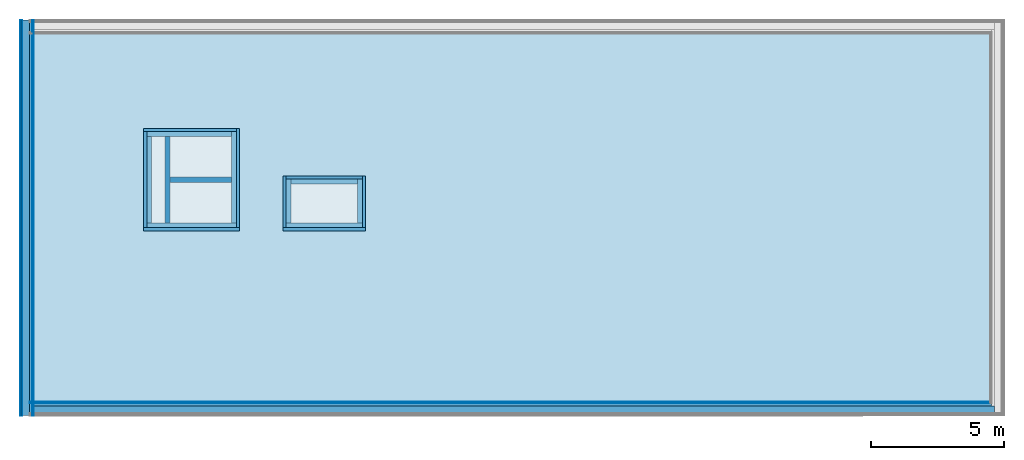
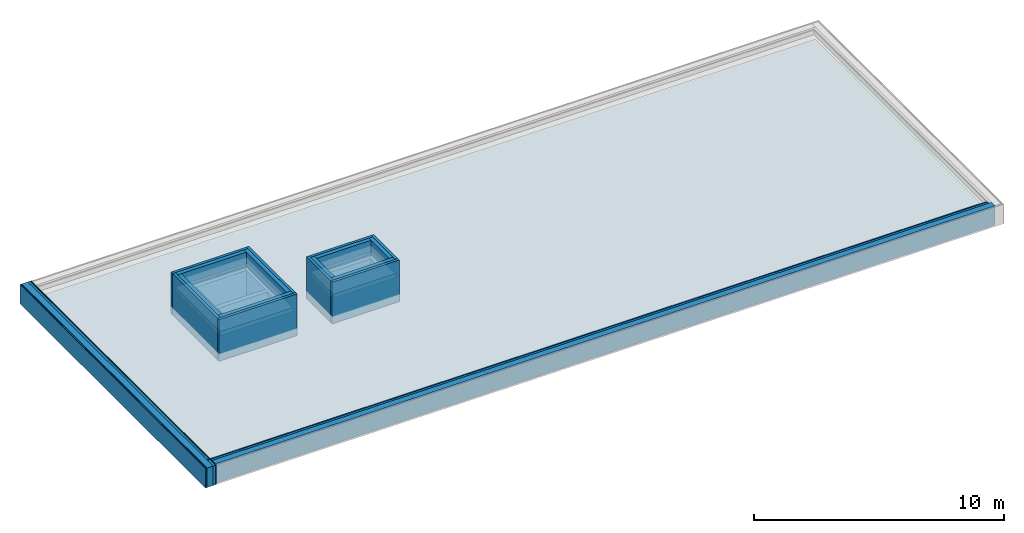
# One storey, part 1 of 3: 29 building element parts, 3 roofs, 2 walls, 10 elements without a shape of their own.
"""IFC4 building model written with IfcOpenShell, lengths in metres."""

from ifc_helpers import new_model, entity, si_unit, converted_unit, derived_unit, direction, frame, origin_with_axes, place, context, subcontext, project, spatial, polygons, material, type_object, element, aggregate, save


model = new_model("IFC4")

# Units and contexts
model_context = context("Model", 3, precision=1e-05, world=origin_with_axes(), true_north=direction((0.0, 1.0)))
body_context = subcontext(model_context, "Body", "Model", "MODEL_VIEW")
ifc_project = project(units=[si_unit("LENGTHUNIT", "METRE"), si_unit("AREAUNIT", "SQUARE_METRE"), si_unit("VOLUMEUNIT", "CUBIC_METRE"), converted_unit("PLANEANGLEUNIT", "DEGREE", entity("IfcPlaneAngleMeasure", 0.0174532925199433), si_unit("PLANEANGLEUNIT", "RADIAN"), dimensions=[0, 0, 0, 0, 0, 0, 0]), converted_unit("TIMEUNIT", "Year", entity("IfcTimeMeasure", 31557600.0), si_unit("TIMEUNIT", "SECOND"), dimensions=[0, 0, 1, 0, 0, 0, 0]), si_unit("MASSUNIT", "GRAM", prefix="KILO"), si_unit("THERMODYNAMICTEMPERATUREUNIT", "DEGREE_CELSIUS"), si_unit("LUMINOUSINTENSITYUNIT", "LUMEN"), si_unit("ENERGYUNIT", "JOULE", prefix="MEGA"), derived_unit("THERMALCONDUCTANCEUNIT", [(si_unit("POWERUNIT", "WATT"), 1), (si_unit("LENGTHUNIT", "METRE"), -1), (si_unit("THERMODYNAMICTEMPERATUREUNIT", "KELVIN"), -1)]), derived_unit("SPECIFICHEATCAPACITYUNIT", [(si_unit("ENERGYUNIT", "JOULE"), 1), (si_unit("MASSUNIT", "GRAM", prefix="KILO"), -1), (si_unit("THERMODYNAMICTEMPERATUREUNIT", "KELVIN"), -1)]), derived_unit("MASSDENSITYUNIT", [(si_unit("MASSUNIT", "GRAM", prefix="KILO"), 1), (si_unit("VOLUMEUNIT", "CUBIC_METRE"), -1)])], contexts=[model_context])

# Site, building, storey
site_placement = place(None, origin_with_axes())
site = spatial("IfcSite", under=ifc_project, at=site_placement, CompositionType="ELEMENT")
building_placement = place(site_placement, origin_with_axes())
building = spatial("IfcBuilding", under=site, at=building_placement, CompositionType="ELEMENT")
storey_placement = place(building_placement, frame((0.0, 0.0, 13.5), z_axis=(0.0, 0.0, 1.0), x_axis=(1.0, 0.0, 0.0)))
storey = spatial("IfcBuildingStorey", under=building, at=storey_placement, Name="Dach", CompositionType="ELEMENT", Elevation=13.5)

# Walls
ifc_material_1 = material(Name="Stahlbeton")
wall_type_1 = type_object("IfcWallType", Name="Stahlbeton 200", PredefinedType="NOTDEFINED")
wall_1_placement = place(storey_placement, frame((29.138, 8.85499994546755, 0.0), z_axis=(0.0, 0.0, 1.0), x_axis=(1.0, 0.0, 0.0)))
element("IfcWall", 1, at=wall_1_placement, inside=storey, type_object=wall_type_1, material=ifc_material_1, Name="Wand-001", PredefinedType="NOTDEFINED", context=body_context, shape_type="Tessellation", body=[
    polygons([(0.0, 0.0999999999999996, 0.0), (2.32, 0.0999999999999996, 0.0), (2.32, -0.0999999999999996, 0.0), (0.0, -0.0999999999999996, 0.0), (0.0, 0.0999999999999996, 1.5), (2.32, 0.0999999999999996, 1.5), (2.32, -0.0999999999999996, 1.5), (0.0, -0.0999999999999996, 1.5)], [[[1, 2, 3, 4]], [[5, 6, 2, 1]], [[7, 3, 2, 6]], [[4, 3, 7, 8]], [[8, 5, 1, 4]], [[8, 7, 6, 5]]], closed=True),
])
wall_type_2 = type_object("IfcWallType", Name="Stahlbeton 180", PredefinedType="NOTDEFINED")
wall_2_placement = place(storey_placement, frame((29.138, 6.93499994546755, 0.0), z_axis=(0.0, 0.0, 1.0), x_axis=(0.0, 1.0, 0.0)))
element("IfcWall", 2, at=wall_2_placement, inside=storey, type_object=wall_type_2, material=ifc_material_1, Name="Wand-001", PredefinedType="NOTDEFINED", context=body_context, shape_type="Tessellation", body=[
    polygons([(0.3, 0.18, 0.0), (3.54, 0.18, 0.0), (3.54, 0.0, 0.0), (0.3, 0.0, 0.0), (0.3, 0.18, 1.5), (3.54, 0.18, 1.5), (3.54, 0.0, 1.5), (0.3, 0.0, 1.5)], [[[1, 2, 3, 4]], [[5, 6, 2, 1]], [[7, 3, 2, 6]], [[4, 3, 7, 8]], [[8, 5, 1, 4]], [[8, 7, 6, 5]]], closed=True),
])

# Roofs
ifc_material_2 = material(Name="Stahlbeton Decke")
roof_type_1 = type_object("IfcRoofType", Name="Stahlbeton Decke 370", PredefinedType="FLAT_ROOF")
roof_1_placement = place(storey_placement, frame((23.888, 0.362999999999999, 0.370000000000001), z_axis=(0.0, 0.0, 1.0), x_axis=(1.0, 0.0, 0.0)))
element("IfcRoof", 3, at=roof_1_placement, inside=storey, type_object=roof_type_1, material=ifc_material_2, Name="Decke-001", PredefinedType="FLAT_ROOF", context=body_context, shape_type="Tessellation", body=[
    polygons([(0.0, 0.0, 0.0), (0.0, 0.0, -0.369999999999999), (36.195, 0.0, -0.369999999999999), (36.195, 0.0, 0.0), (0.0, 14.1199998909351, 0.0), (0.0, 14.1199998909351, -0.369999999999999), (36.195, 14.1199998909351, -0.369999999999999), (7.75000000000001, 10.2919999454676, -0.369999999999999), (4.39000000000001, 10.2919999454676, -0.369999999999999), (4.39000000000001, 6.69199994546756, -0.369999999999999), (7.75000000000001, 6.69199994546756, -0.369999999999999), (12.485, 6.69199994546755, -0.369999999999999), (12.485, 8.50999994546756, -0.369999999999999), (9.617, 8.50999994546756, -0.369999999999999), (9.617, 6.69199994546755, -0.369999999999999), (36.195, 14.1199998909351, 0.0), (4.39000000000001, 6.69199994546756, 0.0), (4.39000000000001, 10.2919999454676, 0.0), (7.75000000000001, 10.2919999454676, 0.0), (7.75000000000001, 6.69199994546756, 0.0), (9.617, 8.50999994546756, 0.0), (12.485, 8.50999994546756, 0.0), (12.485, 6.69199994546755, 0.0), (9.617, 6.69199994546755, 0.0)], [[[1, 2, 3, 4]], [[5, 6, 2, 1]], [[3, 2, 6, 7], [8, 9, 10, 11], [12, 13, 14, 15]], [[4, 3, 7, 16]], [[5, 1, 4, 16], [17, 18, 19, 20], [21, 22, 23, 24]], [[16, 7, 6, 5]], [[18, 9, 8, 19]], [[17, 10, 9, 18]], [[20, 11, 10, 17]], [[19, 8, 11, 20]], [[22, 13, 12, 23]], [[21, 14, 13, 22]], [[24, 15, 14, 21]], [[23, 12, 15, 24]]], closed=True),
])
roof_type_2 = type_object("IfcRoofType", Name="Stahlbeton Decke 200", PredefinedType="FLAT_ROOF")
roof_2_placement = place(storey_placement, frame((28.278, 7.05499994546756, 1.7), z_axis=(0.0, 0.0, 1.0), x_axis=(1.0, 0.0, 0.0)))
element("IfcRoof", 4, at=roof_2_placement, inside=storey, type_object=roof_type_2, material=ifc_material_2, Name="Decke-001", PredefinedType="FLAT_ROOF", context=body_context, shape_type="Tessellation", body=[
    polygons([(0.0, 0.0, 0.0), (0.0, 0.0, -0.199999999999999), (3.36, 0.0, -0.199999999999999), (3.36, 0.0, 0.0), (0.0, 3.59999999999999, 0.0), (0.0, 3.59999999999999, -0.199999999999999), (3.36, 3.59999999999999, -0.199999999999999), (3.36, 3.59999999999999, 0.0)], [[[1, 2, 3, 4]], [[5, 6, 2, 1]], [[3, 2, 6, 7]], [[4, 3, 7, 8]], [[5, 1, 4, 8]], [[8, 7, 6, 5]]], closed=True),
])
roof_3_placement = place(storey_placement, frame((33.505, 7.05499994546756, 1.7), z_axis=(0.0, 0.0, 1.0), x_axis=(1.0, 0.0, 0.0)))
element("IfcRoof", 5, at=roof_3_placement, inside=storey, type_object=roof_type_2, material=ifc_material_2, Name="Decke-001", PredefinedType="FLAT_ROOF", context=body_context, shape_type="Tessellation", body=[
    polygons([(0.0, 0.0, 0.0), (0.0, 0.0, -0.199999999999999), (2.868, 0.0, -0.199999999999999), (2.868, 0.0, 0.0), (0.0, 1.818, 0.0), (0.0, 1.818, -0.199999999999999), (2.868, 1.818, -0.199999999999999), (2.868, 1.818, 0.0)], [[[1, 2, 3, 4]], [[5, 6, 2, 1]], [[3, 2, 6, 7]], [[4, 3, 7, 8]], [[5, 1, 4, 8]], [[8, 7, 6, 5]]], closed=True),
])

# Wall, building element parts
wall_type_3 = type_object("IfcWallType", Name="AW 300", PredefinedType="NOTDEFINED")
wall_3_placement = place(storey_placement, frame((28.158, 6.93499994546755, 0.0), z_axis=(0.0, 0.0, 1.0), x_axis=(1.0, 0.0, 0.0)))
wall_3 = element("IfcWall", 6, at=wall_3_placement, inside=storey, type_object=wall_type_3, Name="Wand-001", PredefinedType="NOTDEFINED")
ifc_material_3 = material(Name="Stahlbeton Wand")
building_element_part_1_placement = place(wall_3_placement, origin_with_axes())
building_element_part_1 = element("IfcBuildingElementPart", 7, at=building_element_part_1_placement, material=ifc_material_3, Name="Stahlbeton Wand", PredefinedType="NOTDEFINED", context=body_context, shape_type="Tessellation", body=[
    polygons([(0.120000000000005, 0.3, 1.5), (3.48, 0.300000000000002, 1.5), (3.48, 0.300000000000001, 0.0), (0.119999999999997, 0.3, 0.0), (3.48, 0.120000000000005, 1.5), (0.120000000000008, 0.120000000000004, 1.5), (3.48, 0.120000000000001, 0.0), (0.120000000000001, 0.12, 0.0)], [[[1, 2, 3, 4]], [[5, 2, 1, 6]], [[2, 5, 7, 3]], [[3, 7, 8, 4]], [[6, 1, 4, 8]], [[5, 6, 8, 7]]], closed=True),
    polygons([(3.48, 0.120000000000005, 1.7), (3.48, 0.300000000000002, 1.7), (3.48, 0.300000000000002, 2.4), (3.48, 0.120000000000001, 2.4), (0.120000000000005, 0.3, 1.7), (0.120000000000008, 0.120000000000004, 1.7), (0.119999999999997, 0.3, 2.4), (0.120000000000001, 0.12, 2.4)], [[[1, 2, 3, 4]], [[5, 2, 1, 6]], [[2, 5, 7, 3]], [[4, 3, 7, 8]], [[6, 1, 4, 8]], [[5, 6, 8, 7]]], closed=True),
])
ifc_material_4 = material(Name="XPS")
building_element_part_2_placement = place(wall_3_placement, origin_with_axes())
building_element_part_2 = element("IfcBuildingElementPart", 8, at=building_element_part_2_placement, material=ifc_material_4, Name="XPS", PredefinedType="NOTDEFINED", context=body_context, shape_type="Tessellation", body=[
    polygons([(3.6, 0.0, 0.370000000000001), (3.6, 0.120000000000001, 0.370000000000001), (3.6, 0.120000000000001, 2.4), (3.6, 0.0, 2.4), (3.48, 0.120000000000002, 0.370000000000001), (0.0, 0.0, 0.370000000000001), (0.0, 0.12, 0.370000000000001), (0.120000000000005, 0.120000000000001, 0.370000000000001), (0.0, 0.12, 2.4), (0.0, 0.0, 2.4)], [[[1, 2, 3, 4]], [[5, 2, 1, 6, 7, 8]], [[8, 7, 9, 3, 2, 5]], [[4, 3, 9, 10]], [[6, 1, 4, 10]], [[7, 6, 10, 9]]], closed=True),
])
aggregate(wall_3, [building_element_part_1, building_element_part_2])

# Wall, building element part
wall_4_placement = place(storey_placement, frame((31.758, 6.93499994546755, 0.0), z_axis=(0.0, 0.0, 1.0), x_axis=(0.0, 1.0, 0.0)))
wall_4 = element("IfcWall", 9, at=wall_4_placement, inside=storey, type_object=wall_type_3, Name="Wand-002", PredefinedType="NOTDEFINED")
building_element_part_3_placement = place(wall_4_placement, origin_with_axes())
building_element_part_3 = element("IfcBuildingElementPart", 10, at=building_element_part_3_placement, material=ifc_material_3, Name="Stahlbeton Wand", PredefinedType="NOTDEFINED", context=body_context, shape_type="Tessellation", body=[
    polygons([(3.72, 0.299999999999997, 1.5), (3.72, 0.119999999999997, 1.5), (3.72, 0.119999999999997, 0.0), (3.72, 0.299999999999997, 0.0), (0.3, 0.120000000000001, 1.5), (0.3, 0.300000000000001, 1.5), (0.3, 0.120000000000001, 0.0), (0.3, 0.300000000000001, 0.0)], [[[1, 2, 3, 4]], [[5, 2, 1, 6]], [[2, 5, 7, 3]], [[4, 3, 7, 8]], [[6, 1, 4, 8]], [[5, 6, 8, 7]]], closed=True),
    polygons([(0.3, 0.120000000000001, 1.7), (3.72, 0.119999999999997, 1.7), (3.72, 0.119999999999997, 2.4), (0.3, 0.120000000000001, 2.4), (3.72, 0.299999999999997, 1.7), (0.3, 0.300000000000001, 1.7), (3.72, 0.299999999999997, 2.4), (0.3, 0.300000000000001, 2.4)], [[[1, 2, 3, 4]], [[5, 2, 1, 6]], [[2, 5, 7, 3]], [[3, 7, 8, 4]], [[6, 1, 4, 8]], [[5, 6, 8, 7]]], closed=True),
])

# Wall, building element parts
wall_5_placement = place(storey_placement, frame((31.758, 10.7749999454676, 0.0), z_axis=(0.0, 0.0, 1.0), x_axis=(-1.0, 0.0, 0.0)))
wall_5 = element("IfcWall", 11, at=wall_5_placement, inside=storey, type_object=wall_type_3, Name="Wand-003", PredefinedType="NOTDEFINED")
building_element_part_4_placement = place(wall_5_placement, origin_with_axes())
building_element_part_4 = element("IfcBuildingElementPart", 12, at=building_element_part_4_placement, material=ifc_material_3, Name="Stahlbeton Wand", PredefinedType="NOTDEFINED", context=body_context, shape_type="Tessellation", body=[
    polygons([(3.47999999999999, 0.120000000000005, 1.5), (0.300000000000001, 0.120000000000005, 1.5), (0.300000000000001, 0.119999999999999, 0.0), (3.48, 0.119999999999999, 0.0), (0.300000000000001, 0.300000000000001, 1.5), (3.47999999999999, 0.300000000000001, 1.5), (0.300000000000001, 0.300000000000001, 0.0), (3.48, 0.299999999999999, 0.0)], [[[1, 2, 3, 4]], [[5, 2, 1, 6]], [[2, 5, 7, 3]], [[8, 4, 3, 7]], [[6, 1, 4, 8]], [[5, 6, 8, 7]]], closed=True),
    polygons([(0.300000000000001, 0.300000000000001, 1.7), (0.300000000000001, 0.120000000000005, 1.7), (0.300000000000001, 0.120000000000001, 2.4), (0.300000000000001, 0.300000000000001, 2.4), (3.47999999999999, 0.120000000000005, 1.7), (3.47999999999999, 0.300000000000001, 1.7), (3.48, 0.119999999999999, 2.4), (3.48, 0.300000000000001, 2.4)], [[[1, 2, 3, 4]], [[5, 2, 1, 6]], [[2, 5, 7, 3]], [[7, 8, 4, 3]], [[6, 1, 4, 8]], [[5, 6, 8, 7]]], closed=True),
])
building_element_part_5_placement = place(wall_5_placement, origin_with_axes())
building_element_part_5 = element("IfcBuildingElementPart", 13, at=building_element_part_5_placement, material=ifc_material_4, Name="XPS", PredefinedType="NOTDEFINED", context=body_context, shape_type="Tessellation", body=[
    polygons([(0.119999999999997, 0.120000000000005, 0.370000000000001), (0.120000000000001, 0.0, 0.370000000000001), (0.120000000000001, 0.0, 2.4), (0.120000000000001, 0.120000000000001, 2.4), (3.6, 0.0, 0.370000000000001), (3.48, 0.120000000000005, 0.370000000000001), (3.6, 0.119999999999999, 0.370000000000001), (3.6, 0.0, 2.4), (3.6, 0.119999999999999, 2.4)], [[[1, 2, 3, 4]], [[5, 2, 1, 6, 7]], [[2, 5, 8, 3]], [[8, 9, 4, 3]], [[6, 1, 4, 9, 7]], [[5, 7, 9, 8]]], closed=True),
])
aggregate(wall_5, [building_element_part_4, building_element_part_5])

wall_6_placement = place(storey_placement, frame((28.158, 6.93499994546755, 0.0), z_axis=(0.0, 0.0, 1.0), x_axis=(0.0, 1.0, 0.0)))
wall_6 = element("IfcWall", 14, at=wall_6_placement, inside=storey, type_object=wall_type_3, Name="Wand-002", PredefinedType="NOTDEFINED")
building_element_part_6_placement = place(wall_6_placement, origin_with_axes())
building_element_part_6 = element("IfcBuildingElementPart", 15, at=building_element_part_6_placement, material=ifc_material_4, Name="XPS", PredefinedType="NOTDEFINED", context=body_context, shape_type="Tessellation", body=[
    polygons([(0.120000000000001, -0.120000000000005, 0.370000000000001), (3.72, -0.120000000000001, 0.370000000000001), (3.72, -0.119999999999997, 2.4), (0.12, -0.120000000000001, 2.4), (3.72, 0.0, 0.370000000000001), (0.12, 0.0, 0.370000000000001), (3.72, 0.0, 2.4), (0.12, 0.0, 2.4)], [[[1, 2, 3, 4]], [[5, 2, 1, 6]], [[2, 5, 7, 3]], [[3, 7, 8, 4]], [[6, 1, 4, 8]], [[5, 6, 8, 7]]], closed=True),
])
building_element_part_7_placement = place(wall_6_placement, origin_with_axes())
building_element_part_7 = element("IfcBuildingElementPart", 16, at=building_element_part_7_placement, material=ifc_material_3, Name="Stahlbeton Wand", PredefinedType="NOTDEFINED", context=body_context, shape_type="Tessellation", body=[
    polygons([(3.54, -0.120000000000005, 1.5), (3.54, -0.299999999999997, 1.5), (3.54, -0.299999999999997, 0.0), (3.54, -0.119999999999997, 0.0), (0.300000000000001, -0.300000000000001, 1.5), (0.3, -0.120000000000008, 1.5), (0.300000000000001, -0.300000000000001, 0.0), (0.3, -0.120000000000001, 0.0)], [[[1, 2, 3, 4]], [[5, 2, 1, 6]], [[2, 5, 7, 3]], [[4, 3, 7, 8]], [[6, 1, 4, 8]], [[5, 6, 8, 7]]], closed=True),
    polygons([(0.300000000000001, -0.300000000000001, 1.7), (3.54, -0.299999999999997, 1.7), (3.54, -0.299999999999997, 2.4), (0.300000000000001, -0.300000000000001, 2.4), (3.54, -0.120000000000005, 1.7), (0.3, -0.120000000000008, 1.7), (3.54, -0.119999999999997, 2.4), (0.3, -0.120000000000001, 2.4)], [[[1, 2, 3, 4]], [[5, 2, 1, 6]], [[2, 5, 7, 3]], [[3, 7, 8, 4]], [[6, 1, 4, 8]], [[5, 6, 8, 7]]], closed=True),
])
aggregate(wall_6, [building_element_part_6, building_element_part_7])

# Building element part
building_element_part_8_placement = place(wall_4_placement, origin_with_axes())
building_element_part_8 = element("IfcBuildingElementPart", 17, at=building_element_part_8_placement, material=ifc_material_4, Name="XPS", PredefinedType="NOTDEFINED", context=body_context, shape_type="Tessellation", body=[
    polygons([(0.12, 0.0, 0.370000000000001), (3.84, 0.0, 0.370000000000001), (3.84, 0.0, 2.4), (0.12, 0.0, 2.4), (3.84, 0.119999999999997, 0.370000000000001), (0.120000000000002, 0.120000000000001, 0.370000000000001), (3.72, 0.119999999999997, 0.370000000000001), (3.84, 0.119999999999997, 2.4), (0.12, 0.120000000000001, 2.4)], [[[1, 2, 3, 4]], [[5, 2, 1, 6, 7]], [[2, 5, 8, 3]], [[3, 8, 9, 4]], [[6, 1, 4, 9]], [[7, 6, 9, 8, 5]]], closed=True),
])

aggregate(wall_4, [building_element_part_3, building_element_part_8])

# Wall, building element parts
wall_7_placement = place(storey_placement, frame((36.493, 6.93499994546756, 0.0), z_axis=(0.0, 0.0, 1.0), x_axis=(0.0, 1.0, 0.0)))
wall_7 = element("IfcWall", 18, at=wall_7_placement, inside=storey, type_object=wall_type_3, Name="Wand-002", PredefinedType="NOTDEFINED")
building_element_part_9_placement = place(wall_7_placement, origin_with_axes())
building_element_part_9 = element("IfcBuildingElementPart", 19, at=building_element_part_9_placement, material=ifc_material_3, Name="Stahlbeton Wand", PredefinedType="NOTDEFINED", context=body_context, shape_type="Tessellation", body=[
    polygons([(1.93800000000001, 0.299999999999997, 1.5), (1.93800000000001, 0.119999999999997, 1.5), (1.93800000000001, 0.119999999999997, 0.0), (1.93800000000001, 0.299999999999997, 0.0), (0.3, 0.119999999999997, 1.5), (0.3, 0.299999999999997, 1.5), (0.3, 0.119999999999997, 0.0), (0.3, 0.299999999999997, 0.0)], [[[1, 2, 3, 4]], [[5, 2, 1, 6]], [[2, 5, 7, 3]], [[4, 3, 7, 8]], [[6, 1, 4, 8]], [[5, 6, 8, 7]]], closed=True),
    polygons([(0.3, 0.119999999999997, 1.7), (1.93800000000001, 0.119999999999997, 1.7), (1.93800000000001, 0.119999999999997, 2.4), (0.3, 0.119999999999997, 2.4), (1.93800000000001, 0.299999999999997, 1.7), (0.3, 0.299999999999997, 1.7), (1.93800000000001, 0.299999999999997, 2.4), (0.3, 0.299999999999997, 2.4)], [[[1, 2, 3, 4]], [[5, 2, 1, 6]], [[2, 5, 7, 3]], [[3, 7, 8, 4]], [[6, 1, 4, 8]], [[5, 6, 8, 7]]], closed=True),
])
building_element_part_10_placement = place(wall_7_placement, origin_with_axes())
building_element_part_10 = element("IfcBuildingElementPart", 20, at=building_element_part_10_placement, material=ifc_material_4, Name="XPS", PredefinedType="NOTDEFINED", context=body_context, shape_type="Tessellation", body=[
    polygons([(0.12, 0.0, 0.370000000000001), (2.058, 0.0, 0.370000000000001), (2.058, 0.0, 2.4), (0.12, 0.0, 2.4), (2.058, 0.119999999999997, 0.370000000000001), (0.119999999999997, 0.119999999999997, 0.370000000000001), (1.93800000000001, 0.119999999999997, 0.370000000000001), (2.058, 0.119999999999997, 2.4), (0.12, 0.119999999999997, 2.4)], [[[1, 2, 3, 4]], [[5, 2, 1, 6, 7]], [[2, 5, 8, 3]], [[3, 8, 9, 4]], [[6, 1, 4, 9]], [[7, 6, 9, 8, 5]]], closed=True),
])
aggregate(wall_7, [building_element_part_9, building_element_part_10])

wall_8_placement = place(storey_placement, frame((36.493, 8.99299994546756, 0.0), z_axis=(0.0, 0.0, 1.0), x_axis=(-1.0, 0.0, 0.0)))
wall_8 = element("IfcWall", 21, at=wall_8_placement, inside=storey, type_object=wall_type_3, Name="Wand-002", PredefinedType="NOTDEFINED")
building_element_part_11_placement = place(wall_8_placement, origin_with_axes())
building_element_part_11 = element("IfcBuildingElementPart", 22, at=building_element_part_11_placement, material=ifc_material_4, Name="XPS", PredefinedType="NOTDEFINED", context=body_context, shape_type="Tessellation", body=[
    polygons([(0.119999999999997, 0.119999999999999, 0.370000000000001), (0.119999999999997, 0.0, 0.370000000000001), (0.119999999999997, 0.0, 2.4), (0.119999999999997, 0.120000000000001, 2.4), (2.988, 0.0, 0.370000000000001), (2.988, 0.119999999999999, 0.370000000000001), (2.988, 0.0, 2.4), (2.988, 0.119999999999999, 2.4)], [[[1, 2, 3, 4]], [[5, 2, 1, 6]], [[2, 5, 7, 3]], [[7, 8, 4, 3]], [[6, 1, 4, 8]], [[5, 6, 8, 7]]], closed=True),
])
building_element_part_12_placement = place(wall_8_placement, origin_with_axes())
building_element_part_12 = element("IfcBuildingElementPart", 23, at=building_element_part_12_placement, material=ifc_material_3, Name="Stahlbeton Wand", PredefinedType="NOTDEFINED", context=body_context, shape_type="Tessellation", body=[
    polygons([(2.808, 0.119999999999999, 1.5), (0.299999999999997, 0.119999999999999, 1.5), (0.299999999999997, 0.119999999999999, 0.0), (2.808, 0.119999999999999, 0.0), (0.299999999999997, 0.300000000000001, 1.5), (2.808, 0.300000000000001, 1.5), (0.299999999999997, 0.300000000000001, 0.0), (2.808, 0.299999999999999, 0.0)], [[[1, 2, 3, 4]], [[5, 2, 1, 6]], [[2, 5, 7, 3]], [[8, 4, 3, 7]], [[6, 1, 4, 8]], [[5, 6, 8, 7]]], closed=True),
    polygons([(0.299999999999997, 0.300000000000001, 1.7), (0.299999999999997, 0.119999999999999, 1.7), (0.299999999999997, 0.120000000000001, 2.4), (0.299999999999997, 0.300000000000001, 2.4), (2.808, 0.119999999999999, 1.7), (2.808, 0.300000000000001, 1.7), (2.808, 0.119999999999999, 2.4), (2.808, 0.300000000000001, 2.4)], [[[1, 2, 3, 4]], [[5, 2, 1, 6]], [[2, 5, 7, 3]], [[7, 8, 4, 3]], [[6, 1, 4, 8]], [[5, 6, 8, 7]]], closed=True),
])
aggregate(wall_8, [building_element_part_11, building_element_part_12])

# Wall, building element part
wall_9_placement = place(storey_placement, frame((33.385, 6.93499994546756, 0.0), z_axis=(0.0, 0.0, 1.0), x_axis=(1.0, 0.0, 0.0)))
wall_9 = element("IfcWall", 24, at=wall_9_placement, inside=storey, type_object=wall_type_3, Name="Wand-002", PredefinedType="NOTDEFINED")
building_element_part_13_placement = place(wall_9_placement, origin_with_axes())
building_element_part_13 = element("IfcBuildingElementPart", 25, at=building_element_part_13_placement, material=ifc_material_4, Name="XPS", PredefinedType="NOTDEFINED", context=body_context, shape_type="Tessellation", body=[
    polygons([(3.108, 0.0, 0.370000000000001), (3.108, 0.12, 0.370000000000001), (3.108, 0.12, 2.4), (3.108, 0.0, 2.4), (2.988, 0.119999999999997, 0.370000000000001), (0.0, 0.0, 0.370000000000001), (0.0, 0.12, 0.370000000000001), (0.119999999999997, 0.119999999999997, 0.370000000000001), (0.0, 0.12, 2.4), (0.0, 0.0, 2.4)], [[[1, 2, 3, 4]], [[5, 2, 1, 6, 7, 8]], [[8, 7, 9, 3, 2, 5]], [[4, 3, 9, 10]], [[6, 1, 4, 10]], [[7, 6, 10, 9]]], closed=True),
])

wall_10_placement = place(storey_placement, frame((33.385, 6.93499994546756, 0.0), z_axis=(0.0, 0.0, 1.0), x_axis=(0.0, 1.0, 0.0)))
wall_10 = element("IfcWall", 26, at=wall_10_placement, inside=storey, type_object=wall_type_3, Name="Wand-002", PredefinedType="NOTDEFINED")
building_element_part_14_placement = place(wall_10_placement, origin_with_axes())
building_element_part_14 = element("IfcBuildingElementPart", 27, at=building_element_part_14_placement, material=ifc_material_4, Name="XPS", PredefinedType="NOTDEFINED", context=body_context, shape_type="Tessellation", body=[
    polygons([(0.119999999999997, -0.119999999999997, 0.370000000000001), (1.93800000000001, -0.119999999999997, 0.370000000000001), (2.058, -0.119999999999997, 0.370000000000001), (2.058, -0.119999999999997, 2.4), (0.12, -0.119999999999997, 2.4), (2.058, 0.0, 0.370000000000001), (0.12, 0.0, 0.370000000000001), (2.058, 0.0, 2.4), (0.12, 0.0, 2.4)], [[[1, 2, 3, 4, 5]], [[6, 3, 2, 1, 7]], [[3, 6, 8, 4]], [[4, 8, 9, 5]], [[7, 1, 5, 9]], [[6, 7, 9, 8]]], closed=True),
])

# Building element part
building_element_part_15_placement = place(wall_9_placement, origin_with_axes())
building_element_part_15 = element("IfcBuildingElementPart", 28, at=building_element_part_15_placement, material=ifc_material_3, Name="Stahlbeton Wand", PredefinedType="NOTDEFINED", context=body_context, shape_type="Tessellation", body=[
    polygons([(0.119999999999997, 0.3, 1.5), (2.988, 0.300000000000001, 1.5), (2.988, 0.3, 0.0), (0.119999999999997, 0.3, 0.0), (2.988, 0.120000000000002, 1.5), (0.119999999999997, 0.120000000000002, 1.5), (2.988, 0.12, 0.0), (0.119999999999997, 0.12, 0.0)], [[[1, 2, 3, 4]], [[5, 2, 1, 6]], [[2, 5, 7, 3]], [[3, 7, 8, 4]], [[6, 1, 4, 8]], [[5, 6, 8, 7]]], closed=True),
    polygons([(2.988, 0.120000000000002, 1.7), (2.988, 0.300000000000001, 1.7), (2.988, 0.300000000000001, 2.4), (2.988, 0.12, 2.4), (0.119999999999997, 0.3, 1.7), (0.119999999999997, 0.120000000000002, 1.7), (0.119999999999997, 0.3, 2.4), (0.119999999999997, 0.12, 2.4)], [[[1, 2, 3, 4]], [[5, 2, 1, 6]], [[2, 5, 7, 3]], [[4, 3, 7, 8]], [[6, 1, 4, 8]], [[5, 6, 8, 7]]], closed=True),
])

aggregate(wall_9, [building_element_part_13, building_element_part_15])

building_element_part_16_placement = place(wall_10_placement, origin_with_axes())
building_element_part_16 = element("IfcBuildingElementPart", 29, at=building_element_part_16_placement, material=ifc_material_3, Name="Stahlbeton Wand", PredefinedType="NOTDEFINED", context=body_context, shape_type="Tessellation", body=[
    polygons([(1.93800000000001, -0.119999999999997, 1.5), (1.93800000000001, -0.299999999999997, 1.5), (1.93800000000001, -0.299999999999997, 0.0), (1.93800000000001, -0.119999999999997, 0.0), (0.3, -0.299999999999997, 1.5), (0.3, -0.119999999999997, 1.5), (0.3, -0.299999999999997, 0.0), (0.3, -0.119999999999997, 0.0)], [[[1, 2, 3, 4]], [[5, 2, 1, 6]], [[2, 5, 7, 3]], [[4, 3, 7, 8]], [[6, 1, 4, 8]], [[5, 6, 8, 7]]], closed=True),
    polygons([(0.3, -0.299999999999997, 1.7), (1.93800000000001, -0.299999999999997, 1.7), (1.93800000000001, -0.299999999999997, 2.4), (0.3, -0.299999999999997, 2.4), (1.93800000000001, -0.119999999999997, 1.7), (0.3, -0.119999999999997, 1.7), (1.93800000000001, -0.119999999999997, 2.4), (0.3, -0.119999999999997, 2.4)], [[[1, 2, 3, 4]], [[5, 2, 1, 6]], [[2, 5, 7, 3]], [[3, 7, 8, 4]], [[6, 1, 4, 8]], [[5, 6, 8, 7]]], closed=True),
])

aggregate(wall_10, [building_element_part_14, building_element_part_16])

# Wall, building element parts
wall_type_4 = type_object("IfcWallType", Name="04a-00 520", PredefinedType="NOTDEFINED")
wall_11_placement = place(storey_placement, frame((23.888, 0.0, 0.0), z_axis=(0.0, 0.0, 1.0), x_axis=(1.0, 0.0, 0.0)))
wall_11 = element("IfcWall", 30, at=wall_11_placement, inside=storey, type_object=wall_type_4, PredefinedType="NOTDEFINED")
ifc_material_5 = material(Name="din_18948")
building_element_part_17_placement = place(wall_11_placement, origin_with_axes())
building_element_part_17 = element("IfcBuildingElementPart", 31, at=building_element_part_17_placement, material=ifc_material_5, Name="din_18948", PredefinedType="NOTDEFINED", context=body_context, shape_type="Tessellation", body=[
    polygons([(36.043, 0.493000000000002, 0.0), (0.0, 0.493, 0.0), (0.0, 0.515, 0.0), (36.043, 0.515000000000002, 0.0), (36.043, 0.493000000000002, 0.950000000000003), (0.0, 0.493, 0.950000000000003), (0.0, 0.515, 0.950000000000003), (36.043, 0.515000000000002, 0.950000000000003)], [[[1, 2, 3, 4]], [[5, 6, 2, 1]], [[3, 2, 6, 7]], [[4, 3, 7, 8]], [[4, 8, 5, 1]], [[8, 7, 6, 5]]], closed=True),
])
ifc_material_6 = material(Name="holz_fichte")
building_element_part_18_placement = place(wall_11_placement, origin_with_axes())
building_element_part_18 = element("IfcBuildingElementPart", 32, at=building_element_part_18_placement, material=ifc_material_6, Name="holz_fichte", PredefinedType="NOTDEFINED", context=body_context, shape_type="Tessellation", body=[
    polygons([(36.065, 0.463000000000002, 0.0), (0.0, 0.463, 0.0), (0.0, 0.493, 0.0), (36.065, 0.493000000000002, 0.0), (36.065, 0.463000000000002, 0.950000000000003), (0.0, 0.463, 0.950000000000003), (0.0, 0.493, 0.950000000000003), (36.065, 0.493000000000002, 0.950000000000003)], [[[1, 2, 3, 4]], [[5, 6, 2, 1]], [[3, 2, 6, 7]], [[4, 3, 7, 8]], [[4, 8, 5, 1]], [[8, 7, 6, 5]]], closed=True),
])
ifc_material_7 = material(Name="5")
building_element_part_19_placement = place(wall_11_placement, origin_with_axes())
building_element_part_19 = element("IfcBuildingElementPart", 33, at=building_element_part_19_placement, material=ifc_material_7, Name="5", PredefinedType="NOTDEFINED", context=body_context, shape_type="Tessellation", body=[
    polygons([(36.095, 0.363000000000002, 0.0), (0.0, 0.363, 0.0), (0.0, 0.463, 0.0), (36.095, 0.463000000000002, 0.0), (36.095, 0.363000000000002, 0.950000000000003), (0.0, 0.363, 0.950000000000003), (0.0, 0.463, 0.950000000000003), (36.095, 0.463000000000002, 0.950000000000003)], [[[1, 2, 3, 4]], [[5, 6, 2, 1]], [[3, 2, 6, 7]], [[4, 3, 7, 8]], [[4, 8, 5, 1]], [[8, 7, 6, 5]]], closed=True),
])
ifc_material_8 = material(Name="mit")
building_element_part_20_placement = place(wall_11_placement, origin_with_axes())
building_element_part_20 = element("IfcBuildingElementPart", 34, at=building_element_part_20_placement, material=ifc_material_8, Name="mit", PredefinedType="NOTDEFINED", context=body_context, shape_type="Tessellation", body=[
    polygons([(36.038, 0.515000000000002, 0.0), (0.0, 0.515, 0.0), (0.0, 0.52, 0.0), (36.038, 0.520000000000002, 0.0), (36.038, 0.515000000000002, 0.950000000000003), (0.0, 0.515, 0.950000000000003), (0.0, 0.52, 0.950000000000003), (36.038, 0.520000000000002, 0.950000000000003)], [[[1, 2, 3, 4]], [[5, 6, 2, 1]], [[3, 2, 6, 7]], [[4, 3, 7, 8]], [[4, 8, 5, 1]], [[8, 7, 6, 5]]], closed=True),
])
ifc_material_9 = material()
building_element_part_21_placement = place(wall_11_placement, origin_with_axes())
building_element_part_21 = element("IfcBuildingElementPart", 35, at=building_element_part_21_placement, material=ifc_material_9, PredefinedType="NOTDEFINED", context=body_context, shape_type="Tessellation", body=[
    polygons([(36.195, 0.0830000000000022, 0.0), (0.0, 0.083, 0.0), (0.0, 0.363, 0.0), (36.195, 0.363000000000002, 0.0), (36.195, 0.0830000000000023, 0.950000000000003), (0.0, 0.0830000000000001, 0.950000000000003), (0.0, 0.363, 0.950000000000003), (36.195, 0.363000000000002, 0.950000000000003)], [[[1, 2, 3, 4]], [[5, 6, 2, 1]], [[3, 2, 6, 7]], [[4, 3, 7, 8]], [[4, 8, 5, 1]], [[8, 7, 6, 5]]], closed=True),
])
aggregate(wall_11, [building_element_part_17, building_element_part_18, building_element_part_19, building_element_part_20, building_element_part_21])

wall_12_placement = place(storey_placement, frame((23.518, 14.8459998854578, 0.0), z_axis=(0.0, 0.0, 1.0), x_axis=(0.0, -1.0, 0.0)))
wall_12 = element("IfcWall", 36, at=wall_12_placement, inside=storey, type_object=wall_type_4, PredefinedType="NOTDEFINED")
building_element_part_22_placement = place(wall_12_placement, origin_with_axes())
building_element_part_22 = element("IfcBuildingElementPart", 37, at=building_element_part_22_placement, material=ifc_material_5, Name="din_18948", PredefinedType="NOTDEFINED", context=body_context, shape_type="Tessellation", body=[
    polygons([(14.8459998854578, 0.515000000000001, 0.0), (14.8459998854578, 0.493000000000002, 0.0), (0.0, 0.492999999999999, 0.0), (0.0, 0.515000000000001, 0.0), (14.8459998854578, 0.515000000000001, 0.950000000000003), (14.8459998854578, 0.493000000000002, 0.950000000000003), (0.0, 0.492999999999999, 0.950000000000003), (0.0, 0.515000000000001, 0.950000000000003)], [[[1, 2, 3, 4]], [[1, 5, 6, 2]], [[2, 6, 7, 3]], [[4, 3, 7, 8]], [[5, 1, 4, 8]], [[6, 5, 8, 7]]], closed=True),
])
building_element_part_23_placement = place(wall_12_placement, origin_with_axes())
building_element_part_23 = element("IfcBuildingElementPart", 38, at=building_element_part_23_placement, material=ifc_material_6, Name="holz_fichte", PredefinedType="NOTDEFINED", context=body_context, shape_type="Tessellation", body=[
    polygons([(14.8459998854578, 0.493000000000002, 0.0), (14.8459998854578, 0.463000000000001, 0.0), (0.0, 0.463000000000001, 0.0), (0.0, 0.492999999999999, 0.0), (14.8459998854578, 0.493000000000002, 0.950000000000003), (14.8459998854578, 0.463000000000001, 0.950000000000003), (0.0, 0.463000000000001, 0.950000000000003), (0.0, 0.492999999999999, 0.950000000000003)], [[[1, 2, 3, 4]], [[1, 5, 6, 2]], [[2, 6, 7, 3]], [[4, 3, 7, 8]], [[5, 1, 4, 8]], [[6, 5, 8, 7]]], closed=True),
])
building_element_part_24_placement = place(wall_12_placement, origin_with_axes())
building_element_part_24 = element("IfcBuildingElementPart", 39, at=building_element_part_24_placement, material=ifc_material_9, PredefinedType="NOTDEFINED", context=body_context, shape_type="Tessellation", body=[
    polygons([(14.8459998854578, 0.363000000000003, 0.0), (14.8459998854578, 0.083000000000002, 0.0), (0.0, 0.0829999999999984, 0.0), (0.0, 0.362999999999999, 0.0), (14.8459998854578, 0.363000000000003, 0.950000000000003), (14.8459998854578, 0.083000000000002, 0.950000000000003), (0.0, 0.0829999999999984, 0.950000000000003), (0.0, 0.362999999999999, 0.950000000000003)], [[[1, 2, 3, 4]], [[1, 5, 6, 2]], [[2, 6, 7, 3]], [[4, 3, 7, 8]], [[5, 1, 4, 8]], [[6, 5, 8, 7]]], closed=True),
])
building_element_part_25_placement = place(wall_12_placement, origin_with_axes())
building_element_part_25 = element("IfcBuildingElementPart", 40, at=building_element_part_25_placement, material=ifc_material_7, Name="5", PredefinedType="NOTDEFINED", context=body_context, shape_type="Tessellation", body=[
    polygons([(14.8459998854578, 0.463000000000001, 0.0), (14.8459998854578, 0.363000000000003, 0.0), (0.0, 0.362999999999999, 0.0), (0.0, 0.463000000000001, 0.0), (14.8459998854578, 0.463000000000001, 0.950000000000003), (14.8459998854578, 0.363000000000003, 0.950000000000003), (0.0, 0.362999999999999, 0.950000000000003), (0.0, 0.463000000000001, 0.950000000000003)], [[[1, 2, 3, 4]], [[1, 5, 6, 2]], [[2, 6, 7, 3]], [[4, 3, 7, 8]], [[5, 1, 4, 8]], [[6, 5, 8, 7]]], closed=True),
])
building_element_part_26_placement = place(wall_12_placement, origin_with_axes())
building_element_part_26 = element("IfcBuildingElementPart", 41, at=building_element_part_26_placement, material=ifc_material_8, Name="mit", PredefinedType="NOTDEFINED", context=body_context, shape_type="Tessellation", body=[
    polygons([(14.8459998854578, 0.520000000000003, 0.0), (14.8459998854578, 0.515000000000001, 0.0), (0.0, 0.515000000000001, 0.0), (0.0, 0.52, 0.0), (14.8459998854578, 0.520000000000003, 0.950000000000003), (14.8459998854578, 0.515000000000001, 0.950000000000003), (0.0, 0.515000000000001, 0.950000000000003), (0.0, 0.52, 0.950000000000003)], [[[1, 2, 3, 4]], [[1, 5, 6, 2]], [[2, 6, 7, 3]], [[4, 3, 7, 8]], [[5, 1, 4, 8]], [[6, 5, 8, 7]]], closed=True),
])
ifc_material_10 = material(Name="fichte")
building_element_part_27_placement = place(wall_12_placement, origin_with_axes())
building_element_part_27 = element("IfcBuildingElementPart", 42, at=building_element_part_27_placement, material=ifc_material_10, Name="fichte", PredefinedType="NOTDEFINED", context=body_context, shape_type="Tessellation", body=[
    polygons([(14.8459998854578, 0.083000000000002, 0.0), (14.8459998854578, 0.0590000000000011, 0.0), (0.0, 0.0590000000000011, 0.0), (0.0, 0.0829999999999984, 0.0), (14.8459998854578, 0.083000000000002, 0.950000000000003), (14.8459998854578, 0.0590000000000011, 0.950000000000003), (0.0, 0.0590000000000011, 0.950000000000003), (0.0, 0.0829999999999984, 0.950000000000003)], [[[1, 2, 3, 4]], [[1, 5, 6, 2]], [[2, 6, 7, 3]], [[4, 3, 7, 8]], [[5, 1, 4, 8]], [[6, 5, 8, 7]]], closed=True),
])
ifc_material_11 = material()
building_element_part_28_placement = place(wall_12_placement, origin_with_axes())
building_element_part_28 = element("IfcBuildingElementPart", 43, at=building_element_part_28_placement, material=ifc_material_11, PredefinedType="NOTDEFINED", context=body_context, shape_type="Tessellation", body=[
    polygons([(14.8459998854578, 0.0190000000000019, 0.0), (14.8459998854578, 0.0, 0.0), (0.0, 0.0, 0.0), (0.0, 0.0189999999999984, 0.0), (14.8459998854578, 0.0190000000000019, 0.950000000000003), (14.8459998854578, 0.0, 0.950000000000003), (0.0, 0.0, 0.950000000000003), (0.0, 0.0189999999999984, 0.950000000000003)], [[[1, 2, 3, 4]], [[1, 5, 6, 2]], [[2, 6, 7, 3]], [[4, 3, 7, 8]], [[5, 1, 4, 8]], [[6, 5, 8, 7]]], closed=True),
])
building_element_part_29_placement = place(wall_12_placement, origin_with_axes())
building_element_part_29 = element("IfcBuildingElementPart", 44, at=building_element_part_29_placement, material=ifc_material_6, Name="holz_fichte", PredefinedType="NOTDEFINED", context=body_context, shape_type="Tessellation", body=[
    polygons([(14.8459998854578, 0.0590000000000011, 0.0), (14.8459998854578, 0.0190000000000019, 0.0), (0.0, 0.0189999999999984, 0.0), (0.0, 0.0590000000000011, 0.0), (14.8459998854578, 0.0590000000000011, 0.950000000000003), (14.8459998854578, 0.0190000000000019, 0.950000000000003), (0.0, 0.0189999999999984, 0.950000000000003), (0.0, 0.0590000000000011, 0.950000000000003)], [[[1, 2, 3, 4]], [[1, 5, 6, 2]], [[2, 6, 7, 3]], [[4, 3, 7, 8]], [[5, 1, 4, 8]], [[6, 5, 8, 7]]], closed=True),
])
aggregate(wall_12, [building_element_part_22, building_element_part_23, building_element_part_24, building_element_part_25, building_element_part_26, building_element_part_27, building_element_part_28, building_element_part_29])

save(model, "model.ifc")
